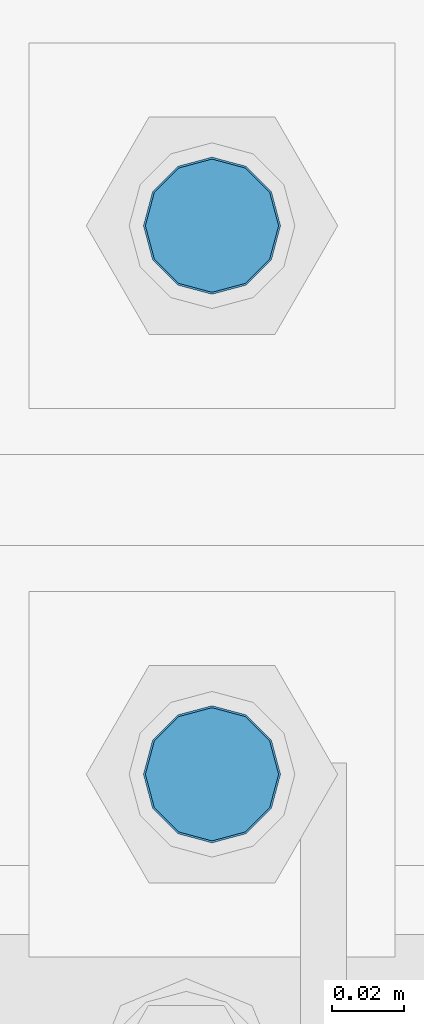
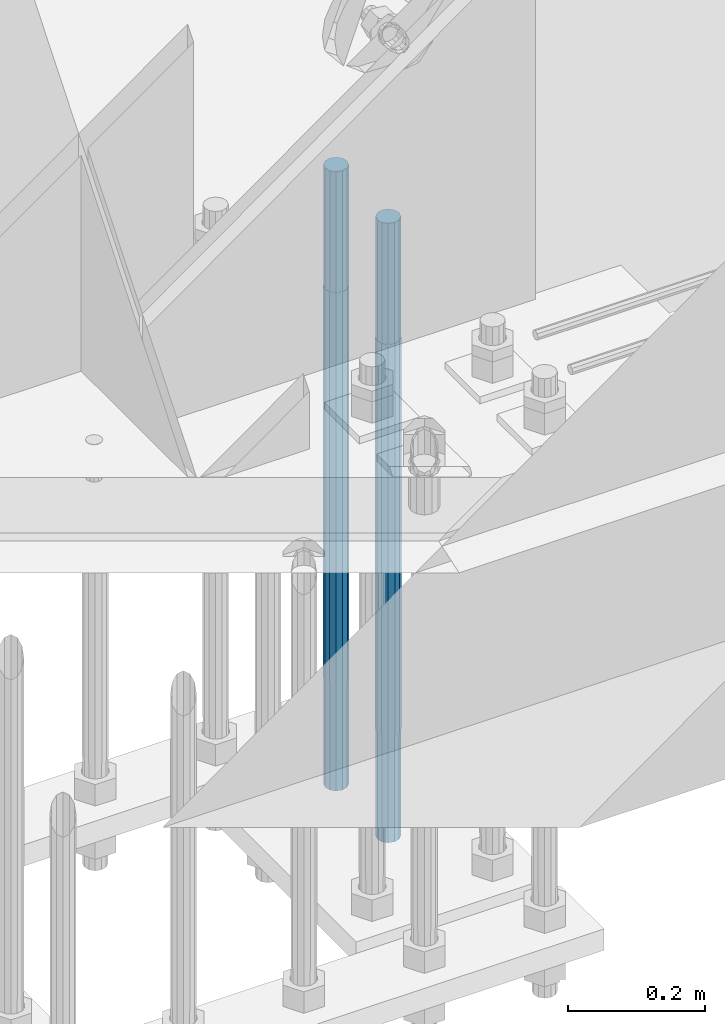
# One storey, part 1284 of 3843: 2 columns, 1 element without a shape of its own.
"""IFC2X3 building model written with IfcOpenShell, lengths in millimetres."""

import ifcopenshell
import ifcopenshell.guid

model = None  # the IFC model being written
_history = None  # IfcOwnerHistory: only IFC2X3 demands one
_inside = {}  # id of a spatial element -> (the spatial element, [elements in it])
_under = {}  # id of a project, library or spatial element -> (it, [spatial elements below it])
_declared = {}  # id of a project -> (the project, [libraries it declares])
_typed = {}  # id of a type object -> (the type object, [elements of that type])
_made_of = {}  # id of a material, layer set ... -> (it, [elements and type objects made of it])


def new_model(schema):
    """Start an empty IFC model of exactly this schema.

    Asked for "IFC4X3", IfcOpenShell would pick the latest addendum, in which some entities
    have other attributes; the version numbers below select the first issue.
    IFC2X3 requires an IfcOwnerHistory on every rooted entity: one is made here for all.
    """
    global model, _history
    if schema == "IFC4X3":
        model = ifcopenshell.file(schema_version=(4, 3, 0, 0))
    else:
        model = ifcopenshell.file(schema=schema)
    _inside.clear()
    _under.clear()
    _declared.clear()
    _typed.clear()
    _made_of.clear()
    _history = None
    if model.schema == "IFC2X3":
        org = make("IfcOrganization", Name="unknown")
        user = make(
            "IfcPersonAndOrganization",
            ThePerson=make("IfcPerson", FamilyName="unknown"),
            TheOrganization=org,
        )
        app = make(
            "IfcApplication",
            ApplicationDeveloper=org,
            Version="unknown",
            ApplicationFullName="unknown",
            ApplicationIdentifier="unknown",
        )
        _history = make(
            "IfcOwnerHistory",
            OwningUser=user,
            OwningApplication=app,
            ChangeAction="ADDED",
            CreationDate=0,
        )
    return model


def make(cls, **values):
    """One entity of the class cls with the attributes given. An attribute that is None is left unset."""
    return model.create_entity(
        cls, **{name: value for name, value in values.items() if value is not None}
    )


def rooted(cls, **values):
    """An entity with a GlobalId (a new one), such as an element, a storey or a relation."""
    return make(cls, GlobalId=ifcopenshell.guid.new(), OwnerHistory=_history, **values)


def si_unit(unit_type, name, prefix=None):
    """IfcSIUnit, for example si_unit("LENGTHUNIT", "METRE", prefix="MILLI")."""
    return make("IfcSIUnit", UnitType=unit_type, Prefix=prefix, Name=name)


def assignment(units):
    """IfcUnitAssignment: the units of a project."""
    return None if units is None else make("IfcUnitAssignment", Units=units)


def point(xyz):
    """IfcCartesianPoint."""
    return None if xyz is None else make("IfcCartesianPoint", Coordinates=xyz)


def direction(xyz):
    """IfcDirection."""
    return None if xyz is None else make("IfcDirection", DirectionRatios=xyz)


def frame(location, z_axis=None, x_axis=None):
    """IfcAxis2Placement3D, a coordinate frame: its origin and axes. An axis left out is left unset."""
    return make(
        "IfcAxis2Placement3D",
        Location=point(location),
        Axis=direction(z_axis),
        RefDirection=direction(x_axis),
    )


def origin_with_axes():
    """The frame at (0, 0, 0) with the z axis (0, 0, 1) and the x axis (1, 0, 0) written out."""
    return frame((0.0, 0.0, 0.0), z_axis=(0.0, 0.0, 1.0), x_axis=(1.0, 0.0, 0.0))


def place(relative_to, where):
    """IfcLocalPlacement: puts the frame where relative to a parent placement (None: the world)."""
    return make(
        "IfcLocalPlacement", PlacementRelTo=relative_to, RelativePlacement=where
    )


def context(
    kind, dimensions, precision=None, world=None, true_north=None, identifier=None
):
    """IfcGeometricRepresentationContext, for example the 3D "Model" context."""
    return make(
        "IfcGeometricRepresentationContext",
        ContextIdentifier=identifier,
        ContextType=kind,
        CoordinateSpaceDimension=dimensions,
        Precision=precision,
        WorldCoordinateSystem=world,
        TrueNorth=true_north,
    )


def subcontext(parent, identifier, kind, view, scale=None):
    """IfcGeometricRepresentationSubContext, for example "Body" below "Model"."""
    return make(
        "IfcGeometricRepresentationSubContext",
        ContextIdentifier=identifier,
        ContextType=kind,
        ParentContext=parent,
        TargetScale=scale,
        TargetView=view,
    )


def project(units=None, contexts=None):
    """IfcProject with its units and contexts."""
    return rooted(
        "IfcProject",
        Name="project",
        RepresentationContexts=contexts,
        UnitsInContext=assignment(units),
    )


def spatial(cls, under=None, at=None, **own):
    """A site, building, storey or space (cls), placed at a placement, below another one or the project."""
    s = rooted(cls, ObjectPlacement=at, **own)
    if under is not None:
        _under.setdefault(under.id(), (under, []))[1].append(s)
    return s


def faces_of(points, faces, orient=None, outer=None):
    """IfcFace entities. A face is a list of loops; a loop is a list of indices into points, from 0.

    orient and outer hold one flag for each loop. By default every Orientation is true, the
    first loop of a face is its IfcFaceOuterBound and the others are IfcFaceBound.
    """
    made = []
    for i, loops in enumerate(faces):
        bounds = []
        for j, loop in enumerate(loops):
            is_outer = j == 0 if outer is None else outer[i][j]
            bounds.append(
                make(
                    "IfcFaceOuterBound" if is_outer else "IfcFaceBound",
                    Bound=make("IfcPolyLoop", Polygon=[points[k] for k in loop]),
                    Orientation=True if orient is None else orient[i][j],
                )
            )
        made.append(make("IfcFace", Bounds=bounds))
    return made


def faceted_brep(points, faces, orient=None, outer=None, voids=None):
    """IfcFacetedBrep: a solid bounded by flat faces; with voids (closed shells), ...WithVoids."""
    shared = [point(p) for p in points]
    hull = make("IfcClosedShell", CfsFaces=faces_of(shared, faces, orient, outer))
    if voids is None:
        return make("IfcFacetedBrep", Outer=hull)
    return make(
        "IfcFacetedBrepWithVoids",
        Outer=hull,
        Voids=[
            make(cls, CfsFaces=faces_of(shared, fs, o, b)) for cls, fs, o, b in voids
        ],
    )


def shape(context_of_items, identifier, shape_type, items):
    """IfcShapeRepresentation: the items that make up one representation, for example the "Body"."""
    return make(
        "IfcShapeRepresentation",
        ContextOfItems=context_of_items,
        RepresentationIdentifier=identifier,
        RepresentationType=shape_type,
        Items=items,
    )


def material(Name=None, Category=None):
    """IfcMaterial."""
    return make("IfcMaterial", Name=Name, Category=Category)


def made_of(thing, what):
    """Note that an element or type object is made of a material, layer set ...; save() writes the relation."""
    if what is not None:
        _made_of.setdefault(what.id(), (what, []))[1].append(thing)
    return thing


def type_object(cls, material=None, **own):
    """A type object (cls), such as IfcWallType, which elements share."""
    return made_of(rooted(cls, **own), material)


def element(
    cls,
    number,
    at=None,
    inside=None,
    cuts=None,
    type_object=None,
    material=None,
    context=None,
    identifier="Body",
    shape_type=None,
    held_by="IfcProductDefinitionShape",
    body=None,
    shapes=None,
    **own,
):
    """One element of the class cls, such as IfcWall. Its Tag is "e" and its number.

    at: its placement. inside: the storey or other place that contains it. cuts: it is an
    opening in that element (IfcRelVoidsElement). A single representation is given by context,
    identifier, shape_type and body (its items); several are given by shapes. held_by: the class
    of the entity that holds the representations. save() writes the other relations.
    """
    e = rooted(cls, Tag="e%d" % number, ObjectPlacement=at, **own)
    if body is not None:
        shapes = [shape(context, identifier, shape_type, body)]
    if shapes is not None:
        e.Representation = make(held_by, Representations=shapes)
    if inside is not None:
        _inside.setdefault(inside.id(), (inside, []))[1].append(e)
    if cuts is not None:
        rooted(
            "IfcRelVoidsElement", RelatingBuildingElement=cuts, RelatedOpeningElement=e
        )
    if type_object is not None:
        _typed.setdefault(type_object.id(), (type_object, []))[1].append(e)
    return made_of(e, material)


def aggregate(whole, parts):
    """IfcRelAggregates: a whole, such as a stair, and the parts it consists of."""
    return rooted("IfcRelAggregates", RelatingObject=whole, RelatedObjects=parts)


def save(model, path):
    """Write the relations noted so far, then the file.

    IfcRelAggregates (storeys below a building ...), IfcRelContainedInSpatialStructure (elements
    in a storey), IfcRelDefinesByType, IfcRelAssociatesMaterial and IfcRelDeclares: one each for
    every whole, place, type object, material and project.
    """
    for whole, parts in _under.values():
        aggregate(whole, parts)
    for where, things in _inside.values():
        rooted(
            "IfcRelContainedInSpatialStructure",
            RelatedElements=things,
            RelatingStructure=where,
        )
    for kind, things in _typed.values():
        rooted("IfcRelDefinesByType", RelatedObjects=things, RelatingType=kind)
    for what, things in _made_of.values():
        rooted("IfcRelAssociatesMaterial", RelatedObjects=things, RelatingMaterial=what)
    for by, libraries in _declared.values():
        rooted("IfcRelDeclares", RelatingContext=by, RelatedDefinitions=libraries)
    model.write(path)


model = new_model("IFC2X3")

# Units and contexts
model_context = context("Model", 3, precision=1e-05, world=origin_with_axes())
body_context = subcontext(model_context, "Body", "Model", "MODEL_VIEW")
ifc_project = project(units=[si_unit("LENGTHUNIT", "METRE", prefix="MILLI"), si_unit("AREAUNIT", "SQUARE_METRE"), si_unit("VOLUMEUNIT", "CUBIC_METRE"), si_unit("MASSUNIT", "GRAM", prefix="KILO"), si_unit("TIMEUNIT", "SECOND"), si_unit("PLANEANGLEUNIT", "RADIAN"), si_unit("SOLIDANGLEUNIT", "STERADIAN"), si_unit("THERMODYNAMICTEMPERATUREUNIT", "DEGREE_CELSIUS"), si_unit("LUMINOUSINTENSITYUNIT", "LUMEN")], contexts=[model_context])

# Site, building, storey
site_placement = place(None, origin_with_axes())
site = spatial("IfcSite", under=ifc_project, at=site_placement, CompositionType="ELEMENT")
building_placement = place(site_placement, origin_with_axes())
building = spatial("IfcBuilding", under=site, at=building_placement, Name="Undefined", CompositionType="ELEMENT")
storey_placement = place(building_placement, origin_with_axes())
storey = spatial("IfcBuildingStorey", under=building, at=storey_placement, Name="Undefined", CompositionType="ELEMENT", Elevation=0.0)

# Assembly, columns
assembly_placement = place(storey_placement, origin_with_axes())
assembly = element("IfcElementAssembly", 1, at=assembly_placement, inside=storey, Name="TEMPLATE", AssemblyPlace="NOTDEFINED", PredefinedType="RIGID_FRAME")
ifc_material = material(Name="Undefined/F1554-GR.55")
column_type = type_object("IfcColumnType", PredefinedType="NOTDEFINED")
column_1_placement = place(assembly_placement, frame((42570.4, 25768.3, 29565.6), z_axis=(0.0, 1.0, 0.0), x_axis=(0.0, 0.0, -1.0)))
column_1 = element("IfcColumn", 2, at=column_1_placement, type_object=column_type, material=ifc_material, Name="ANCHOR_ROD", context=body_context, shape_type="Brep", body=[
    faceted_brep([(-215.899999999998, -16.0214699700118, 9.25), (-215.899999999998, -9.25, 16.0214699700155), (-215.899999999998, 0.0, 18.5), (-215.899999999998, 9.25, 16.0214699700155), (-215.899999999998, 16.0214699700118, 9.25), (-215.899999999998, 18.5, 0.0), (-215.899999999998, 16.0214699700118, -9.25), (-215.899999999998, 9.25, -16.0214699700155), (-215.899999999998, 0.0, -18.5), (-215.899999999998, -9.25, -16.0214699700155), (-215.899999999998, -16.0214699700118, -9.25), (-215.899999999998, -18.5, 0.0), (0.0, 18.5, 0.0), (0.0, 16.0214699700118, -9.25), (0.0, 9.25, -16.0214699700155), (0.0, 0.0, -18.5), (0.0, -9.25, -16.0214699700155), (0.0, -16.0214699700118, -9.25), (0.0, -18.5, 0.0), (0.0, -16.0214699700118, 9.25), (0.0, -9.25, 16.0214699700155), (0.0, 0.0, 18.5), (0.0, 9.25, 16.0214699700155), (0.0, 16.0214699700118, 9.25), (0.0, -16.4977839420972, 9.52500000000146), (0.0, -9.52500000000146, 16.4977839420972), (0.0, 0.0, 19.0499989999989), (0.0, 9.52500000000146, 16.4977839420972), (0.0, 16.4977839420972, 9.52500000000146), (0.0, 19.0500000000029, 0.0), (0.0, 16.4977839420972, -9.52500000000146), (0.0, 9.52500000000146, -16.4977839420972), (0.0, 0.0, -19.0499989999989), (0.0, -9.52500000000146, -16.4977839420972), (0.0, -16.4977839420972, -9.52500000000146), (0.0, -19.0500000000029, 0.0), (698.5, -19.0499999999993, 0.0), (698.5, -16.4977839420935, 9.52499999999418), (698.5, -9.52500000000146, 16.4977839420899), (698.5, 0.0, 19.0500000000029), (698.5, 9.52500000000146, 16.4977839420899), (698.5, 16.4977839420935, 9.52499999999418), (698.5, 19.0499999999993, 0.0), (698.5, 16.4977839420935, -9.52499999999418), (698.5, 9.52500000000146, -16.4977839420899), (698.5, 0.0, -19.0500000000029), (698.5, -9.52500000000146, -16.4977839420899), (698.5, -16.4977839420935, -9.52499999999418), (698.5, -9.25, 16.0214699700155), (698.5, 0.0, 18.5), (698.5, 9.25, 16.0214699700155), (698.5, 16.0214699700118, 9.25), (698.5, 18.5, 0.0), (698.5, 16.0214699700118, -9.25), (698.5, 9.25, -16.0214699700155), (698.5, 0.0, -18.5), (698.5, -9.25, -16.0214699700155), (698.5, -16.0214699700118, -9.25), (698.5, -18.5, 0.0), (698.5, -16.0214699700118, 9.25), (889.0, -9.25, -16.0214699700155), (889.0, 0.0, -18.5), (889.0, 9.25, -16.0214699700155), (889.0, 16.0214699700118, -9.25), (889.0, 18.5, 0.0), (889.0, 16.0214699700118, 9.25), (889.0, 9.25, 16.0214699700155), (889.0, 0.0, 18.5), (889.0, -9.25, 16.0214699700155), (889.0, -16.0214699700118, 9.25), (889.0, -18.5, 0.0), (889.0, -16.0214699700118, -9.25)], [[[0, 1, 2, 3, 4, 5, 6, 7, 8, 9, 10, 11]], [[6, 5, 12, 13]], [[7, 6, 13, 14]], [[8, 7, 14, 15]], [[9, 8, 15, 16]], [[10, 9, 16, 17]], [[11, 10, 17, 18]], [[0, 11, 18, 19]], [[1, 0, 19, 20]], [[2, 1, 20, 21]], [[3, 2, 21, 22]], [[4, 3, 22, 23]], [[5, 4, 23, 12]], [[24, 25, 26, 27, 28, 29, 30, 31, 32, 33, 34, 35], [22, 21, 20, 19, 18, 17, 16, 15, 14, 13, 12, 23]], [[24, 35, 36, 37]], [[25, 24, 37, 38]], [[26, 25, 38, 39]], [[27, 26, 39, 40]], [[28, 27, 40, 41]], [[29, 28, 41, 42]], [[30, 29, 42, 43]], [[31, 30, 43, 44]], [[32, 31, 44, 45]], [[33, 32, 45, 46]], [[34, 33, 46, 47]], [[35, 34, 47, 36]], [[46, 45, 44, 43, 42, 41, 40, 39, 38, 37, 36, 47], [48, 49, 50, 51, 52, 53, 54, 55, 56, 57, 58, 59]], [[60, 61, 62, 63, 64, 65, 66, 67, 68, 69, 70, 71]], [[68, 67, 49, 48]], [[69, 68, 48, 59]], [[70, 69, 59, 58]], [[71, 70, 58, 57]], [[60, 71, 57, 56]], [[61, 60, 56, 55]], [[62, 61, 55, 54]], [[63, 62, 54, 53]], [[64, 63, 53, 52]], [[65, 64, 52, 51]], [[66, 65, 51, 50]], [[67, 66, 50, 49]]]),
])
column_2_placement = place(assembly_placement, frame((42570.4, 25920.7, 29565.6), z_axis=(0.0, 1.0, 0.0), x_axis=(0.0, 0.0, -1.0)))
column_2 = element("IfcColumn", 3, at=column_2_placement, type_object=column_type, material=ifc_material, Name="ANCHOR_ROD", context=body_context, shape_type="Brep", body=[
    faceted_brep([(-215.899999999998, -16.0214699700118, 9.25), (-215.899999999998, -9.25, 16.0214699700155), (-215.899999999998, 0.0, 18.5), (-215.899999999998, 9.25, 16.0214699700155), (-215.899999999998, 16.0214699700118, 9.25), (-215.899999999998, 18.5, 0.0), (-215.899999999998, 16.0214699700118, -9.25), (-215.899999999998, 9.25, -16.0214699700155), (-215.899999999998, 0.0, -18.5), (-215.899999999998, -9.25, -16.0214699700155), (-215.899999999998, -16.0214699700118, -9.25), (-215.899999999998, -18.5, 0.0), (0.0, 18.5, 0.0), (0.0, 16.0214699700118, -9.25), (0.0, 9.25, -16.0214699700155), (0.0, 0.0, -18.5), (0.0, -9.25, -16.0214699700155), (0.0, -16.0214699700118, -9.25), (0.0, -18.5, 0.0), (0.0, -16.0214699700118, 9.25), (0.0, -9.25, 16.0214699700155), (0.0, 0.0, 18.5), (0.0, 9.25, 16.0214699700155), (0.0, 16.0214699700118, 9.25), (0.0, -16.4977839420972, 9.52500000000146), (0.0, -9.52500000000146, 16.4977839420972), (0.0, 0.0, 19.0499989999989), (0.0, 9.52500000000146, 16.4977839420972), (0.0, 16.4977839420972, 9.52500000000146), (0.0, 19.0500000000029, 0.0), (0.0, 16.4977839420972, -9.52500000000146), (0.0, 9.52500000000146, -16.4977839420972), (0.0, 0.0, -19.0499989999989), (0.0, -9.52500000000146, -16.4977839420972), (0.0, -16.4977839420972, -9.52500000000146), (0.0, -19.0500000000029, 0.0), (698.5, -19.0499999999993, 0.0), (698.5, -16.4977839420935, 9.52499999999418), (698.5, -9.52500000000146, 16.4977839420899), (698.5, 0.0, 19.0500000000029), (698.5, 9.52500000000146, 16.4977839420899), (698.5, 16.4977839420935, 9.52499999999418), (698.5, 19.0499999999993, 0.0), (698.5, 16.4977839420935, -9.52499999999418), (698.5, 9.52500000000146, -16.4977839420899), (698.5, 0.0, -19.0500000000029), (698.5, -9.52500000000146, -16.4977839420899), (698.5, -16.4977839420935, -9.52499999999418), (698.5, -9.25, 16.0214699700155), (698.5, 0.0, 18.5), (698.5, 9.25, 16.0214699700155), (698.5, 16.0214699700118, 9.25), (698.5, 18.5, 0.0), (698.5, 16.0214699700118, -9.25), (698.5, 9.25, -16.0214699700155), (698.5, 0.0, -18.5), (698.5, -9.25, -16.0214699700155), (698.5, -16.0214699700118, -9.25), (698.5, -18.5, 0.0), (698.5, -16.0214699700118, 9.25), (889.0, -9.25, -16.0214699700155), (889.0, 0.0, -18.5), (889.0, 9.25, -16.0214699700155), (889.0, 16.0214699700118, -9.25), (889.0, 18.5, 0.0), (889.0, 16.0214699700118, 9.25), (889.0, 9.25, 16.0214699700155), (889.0, 0.0, 18.5), (889.0, -9.25, 16.0214699700155), (889.0, -16.0214699700118, 9.25), (889.0, -18.5, 0.0), (889.0, -16.0214699700118, -9.25)], [[[0, 1, 2, 3, 4, 5, 6, 7, 8, 9, 10, 11]], [[6, 5, 12, 13]], [[7, 6, 13, 14]], [[8, 7, 14, 15]], [[9, 8, 15, 16]], [[10, 9, 16, 17]], [[11, 10, 17, 18]], [[0, 11, 18, 19]], [[1, 0, 19, 20]], [[2, 1, 20, 21]], [[3, 2, 21, 22]], [[4, 3, 22, 23]], [[5, 4, 23, 12]], [[24, 25, 26, 27, 28, 29, 30, 31, 32, 33, 34, 35], [22, 21, 20, 19, 18, 17, 16, 15, 14, 13, 12, 23]], [[24, 35, 36, 37]], [[25, 24, 37, 38]], [[26, 25, 38, 39]], [[27, 26, 39, 40]], [[28, 27, 40, 41]], [[29, 28, 41, 42]], [[30, 29, 42, 43]], [[31, 30, 43, 44]], [[32, 31, 44, 45]], [[33, 32, 45, 46]], [[34, 33, 46, 47]], [[35, 34, 47, 36]], [[46, 45, 44, 43, 42, 41, 40, 39, 38, 37, 36, 47], [48, 49, 50, 51, 52, 53, 54, 55, 56, 57, 58, 59]], [[60, 61, 62, 63, 64, 65, 66, 67, 68, 69, 70, 71]], [[68, 67, 49, 48]], [[69, 68, 48, 59]], [[70, 69, 59, 58]], [[71, 70, 58, 57]], [[60, 71, 57, 56]], [[61, 60, 56, 55]], [[62, 61, 55, 54]], [[63, 62, 54, 53]], [[64, 63, 53, 52]], [[65, 64, 52, 51]], [[66, 65, 51, 50]], [[67, 66, 50, 49]]]),
])
aggregate(assembly, [column_1, column_2])

save(model, "model.ifc")
